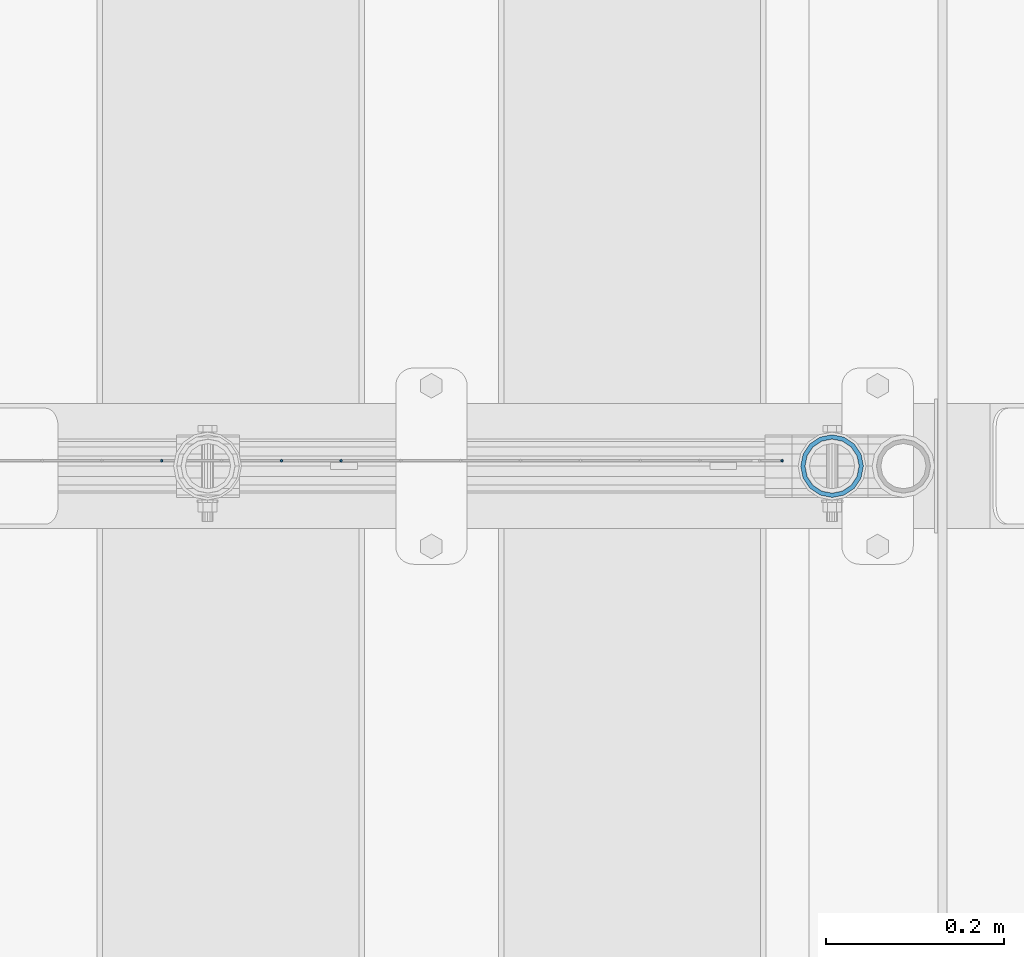
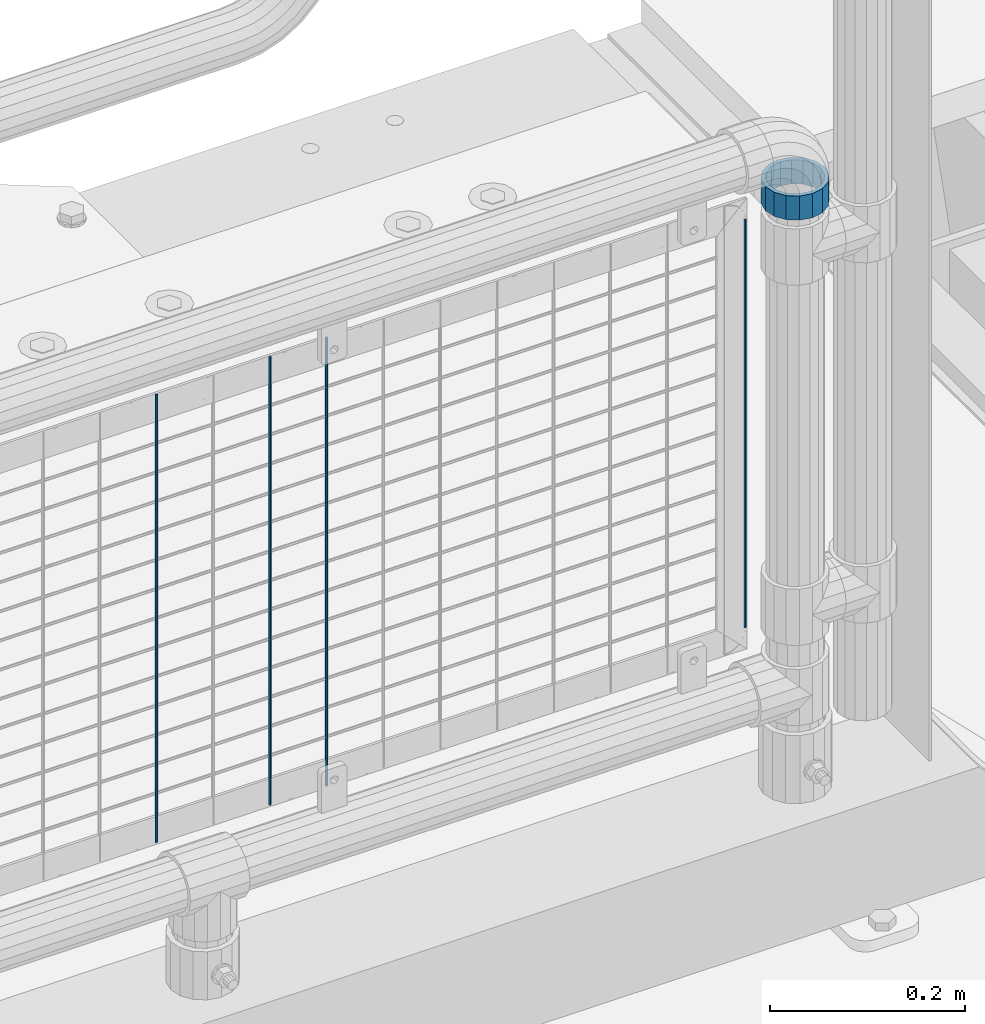
# One storey, part 107 of 242: 5 columns.
"""IFC2X3 building model written with IfcOpenShell, lengths in millimetres."""

from ifc_helpers import new_model, si_unit, frame, origin_with_axes, place, context, subcontext, project, spatial, faceted_brep, material, type_object, element, save


model = new_model("IFC2X3")

# Units and contexts
model_context = context("Model", 3, precision=1e-05, world=origin_with_axes())
body_context = subcontext(model_context, "Body", "Model", "MODEL_VIEW")
ifc_project = project(units=[si_unit("LENGTHUNIT", "METRE", prefix="MILLI"), si_unit("AREAUNIT", "SQUARE_METRE"), si_unit("VOLUMEUNIT", "CUBIC_METRE"), si_unit("MASSUNIT", "GRAM", prefix="KILO"), si_unit("TIMEUNIT", "SECOND"), si_unit("PLANEANGLEUNIT", "RADIAN"), si_unit("SOLIDANGLEUNIT", "STERADIAN"), si_unit("THERMODYNAMICTEMPERATUREUNIT", "DEGREE_CELSIUS"), si_unit("LUMINOUSINTENSITYUNIT", "LUMEN")], contexts=[model_context])

# Site, building, storey
site_placement = place(None, origin_with_axes())
site = spatial("IfcSite", under=ifc_project, at=site_placement, CompositionType="ELEMENT")
building_placement = place(site_placement, origin_with_axes())
building = spatial("IfcBuilding", under=site, at=building_placement, Name="Standard", CompositionType="ELEMENT")
storey_placement = place(building_placement, origin_with_axes())
storey = spatial("IfcBuildingStorey", under=building, at=storey_placement, Name="Undefined", CompositionType="ELEMENT", Elevation=0.0)

# Columns
ifc_material = material(Name="Misc_Undefined")
column_type_1 = type_object("IfcColumnType", PredefinedType="NOTDEFINED")
column_1_placement = place(storey_placement, frame((-22656.0, -19335.5, 894.85), z_axis=(1.0, 0.0, 0.0), x_axis=(0.0, 0.0, 1.0)))
element("IfcColumn", 1, at=column_1_placement, inside=storey, type_object=column_type_1, material=ifc_material, context=body_context, shape_type="Brep", body=[
    faceted_brep([(0.0, -30.3499999999985, 0.0), (0.0, -28.0397438117179, 11.6144421722784), (30.0, -28.0397438117179, 11.6144421722805), (30.0, -30.3499999999985, 0.0), (0.0, -21.46069080901, 21.4606908090136), (30.0, -21.46069080901, 21.4606908090117), (0.0, -11.614442172282, 28.0397438117143), (30.0, -11.614442172282, 28.0397438117176), (0.0, 0.0, 30.3499999999985), (30.0, 0.0, 30.35), (0.0, 11.614442172282, 28.0397438117143), (30.0, 11.614442172282, 28.0397438117176), (0.0, 21.46069080901, 21.4606908090136), (30.0, 21.46069080901, 21.4606908090117), (0.0, 28.0397438117179, 11.6144421722784), (30.0, 28.0397438117179, 11.6144421722805), (0.0, 30.3499999999985, 0.0), (30.0, 30.3499999999985, 0.0), (0.0, 28.0397438117179, -11.6144421722784), (30.0, 28.0397438117179, -11.6144421722805), (0.0, 21.46069080901, -21.4606908090136), (30.0, 21.46069080901, -21.4606908090117), (0.0, 11.614442172282, -28.0397438117143), (30.0, 11.614442172282, -28.0397438117176), (0.0, 0.0, -30.3499999999985), (30.0, 0.0, -30.35), (0.0, -11.614442172282, -28.0397438117143), (30.0, -11.614442172282, -28.0397438117176), (0.0, -21.46069080901, -21.4606908090136), (30.0, -21.46069080901, -21.4606908090117), (0.0, -28.0397438117179, -11.6144421722784), (30.0, -28.0397438117179, -11.6144421722805), (0.0, -35.1500000000015, 0.0), (0.0, -32.4743655677703, -13.4513226476338), (30.0, -32.4743655677703, -13.4513226476329), (30.0, -35.1500000000015, 0.0), (0.0, -24.8548033587067, -24.8548033587067), (30.0, -24.8548033587067, -24.8548033587072), (0.0, -13.4513226476338, -32.4743655677739), (30.0, -13.4513226476338, -32.4743655677718), (0.0, 0.0, -35.1500000000015), (30.0, 0.0, -35.15), (0.0, 13.4513226476338, -32.4743655677739), (30.0, 13.4513226476338, -32.4743655677718), (0.0, 24.8548033587067, -24.8548033587067), (30.0, 24.8548033587067, -24.8548033587072), (0.0, 32.4743655677703, -13.4513226476338), (30.0, 32.4743655677703, -13.4513226476329), (0.0, 35.1500000000015, 0.0), (30.0, 35.1500000000015, 0.0), (0.0, 32.4743655677703, 13.4513226476338), (30.0, 32.4743655677703, 13.4513226476329), (0.0, 24.8548033587067, 24.8548033587067), (30.0, 24.8548033587067, 24.8548033587072), (0.0, 13.4513226476338, 32.4743655677739), (30.0, 13.4513226476338, 32.4743655677718), (0.0, 0.0, 35.1500000000015), (30.0, 0.0, 35.15), (0.0, -13.4513226476338, 32.4743655677739), (30.0, -13.4513226476338, 32.4743655677718), (0.0, -24.8548033587067, 24.8548033587067), (30.0, -24.8548033587067, 24.8548033587072), (0.0, -32.4743655677703, 13.4513226476338), (30.0, -32.4743655677703, 13.4513226476329)], [[[0, 1, 2, 3]], [[1, 4, 5, 2]], [[4, 6, 7, 5]], [[6, 8, 9, 7]], [[8, 10, 11, 9]], [[10, 12, 13, 11]], [[12, 14, 15, 13]], [[14, 16, 17, 15]], [[16, 18, 19, 17]], [[18, 20, 21, 19]], [[20, 22, 23, 21]], [[22, 24, 25, 23]], [[24, 26, 27, 25]], [[26, 28, 29, 27]], [[28, 30, 31, 29]], [[30, 0, 3, 31]], [[32, 33, 34, 35]], [[33, 36, 37, 34]], [[36, 38, 39, 37]], [[38, 40, 41, 39]], [[40, 42, 43, 41]], [[42, 44, 45, 43]], [[44, 46, 47, 45]], [[46, 48, 49, 47]], [[48, 50, 51, 49]], [[50, 52, 53, 51]], [[52, 54, 55, 53]], [[54, 56, 57, 55]], [[56, 58, 59, 57]], [[58, 60, 61, 59]], [[60, 62, 63, 61]], [[62, 32, 35, 63]], [[37, 39, 41, 43, 45, 47, 49, 51, 53, 55, 57, 59, 61, 63, 35, 34], [5, 7, 9, 11, 13, 15, 17, 19, 21, 23, 25, 27, 29, 31, 3, 2]], [[62, 60, 58, 56, 54, 52, 50, 48, 46, 44, 42, 40, 38, 36, 33, 32], [30, 28, 26, 24, 22, 20, 18, 16, 14, 12, 10, 8, 6, 4, 1, 0]]]),
])
column_type_2 = type_object("IfcColumnType", Name="D3", PredefinedType="NOTDEFINED")
for number, where, z_axis, x_axis in (
    (2, (-23407.2779999999, -19329.500073811, 353.02), (-1.0, 0.0, 0.0), (0.0, 0.0, 1.0)),
    (3, (-23273.2219999999, -19329.5001022286, 353.02), (-1.0, 0.0, 0.0), (0.0, 0.0, 1.0)),
    (4, (-23206.1939999999, -19329.5001164374, 353.02), (-1.0, 0.0, 0.0), (0.0, 0.0, 1.0)),
):
    element("IfcColumn", number, at=place(storey_placement, frame(where, z_axis=z_axis, x_axis=x_axis)), inside=storey, type_object=column_type_2, material=ifc_material, ObjectType="D3", context=body_context, shape_type="Brep", body=[
        faceted_brep([(0.0, -1.50000000000364, 0.0), (-3.63797880709171e-12, -0.750000000003638, -1.29903810567669), (560.0, -0.75, -1.29903810567703), (560.0, -1.5, 0.0), (0.0, 0.749999999996362, -1.29903810567669), (560.0, 0.75, -1.29903810567703), (-3.63797880709171e-12, 1.49999999999636, 0.0), (560.0, 1.5, 0.0), (0.0, 0.749999999996362, 1.29903810567669), (560.0, 0.75, 1.29903810567703), (-3.63797880709171e-12, -0.750000000003638, 1.29903810567669), (560.0, -0.75, 1.29903810567703)], [[[0, 1, 2, 3]], [[1, 4, 5, 2]], [[4, 6, 7, 5]], [[6, 8, 9, 7]], [[8, 10, 11, 9]], [[10, 0, 3, 11]], [[5, 7, 9, 11, 3, 2]], [[10, 8, 6, 4, 1, 0]]]),
    ])
column_2_placement = place(storey_placement, frame((-22711.9999999999, -19329.5002211987, 378.02), z_axis=(-1.0, 0.0, 0.0), x_axis=(0.0, 0.0, 1.0)))
element("IfcColumn", 5, at=column_2_placement, inside=storey, type_object=column_type_2, material=ifc_material, ObjectType="D3", context=body_context, shape_type="Brep", body=[
    faceted_brep([(0.0, -1.50000000000364, 0.0), (-3.63797880709171e-12, -0.750000000003638, -1.29903810567669), (510.0, -0.75, -1.29903810567703), (510.0, -1.5, 0.0), (0.0, 0.749999999996362, -1.29903810567669), (510.0, 0.75, -1.29903810567703), (-3.63797880709171e-12, 1.49999999999636, 0.0), (510.0, 1.5, 0.0), (0.0, 0.749999999996362, 1.29903810567669), (510.0, 0.75, 1.29903810567703), (-3.63797880709171e-12, -0.750000000003638, 1.29903810567669), (510.0, -0.75, 1.29903810567703)], [[[0, 1, 2, 3]], [[1, 4, 5, 2]], [[4, 6, 7, 5]], [[6, 8, 9, 7]], [[8, 10, 11, 9]], [[10, 0, 3, 11]], [[5, 7, 9, 11, 3, 2]], [[10, 8, 6, 4, 1, 0]]]),
])

save(model, "model.ifc")
